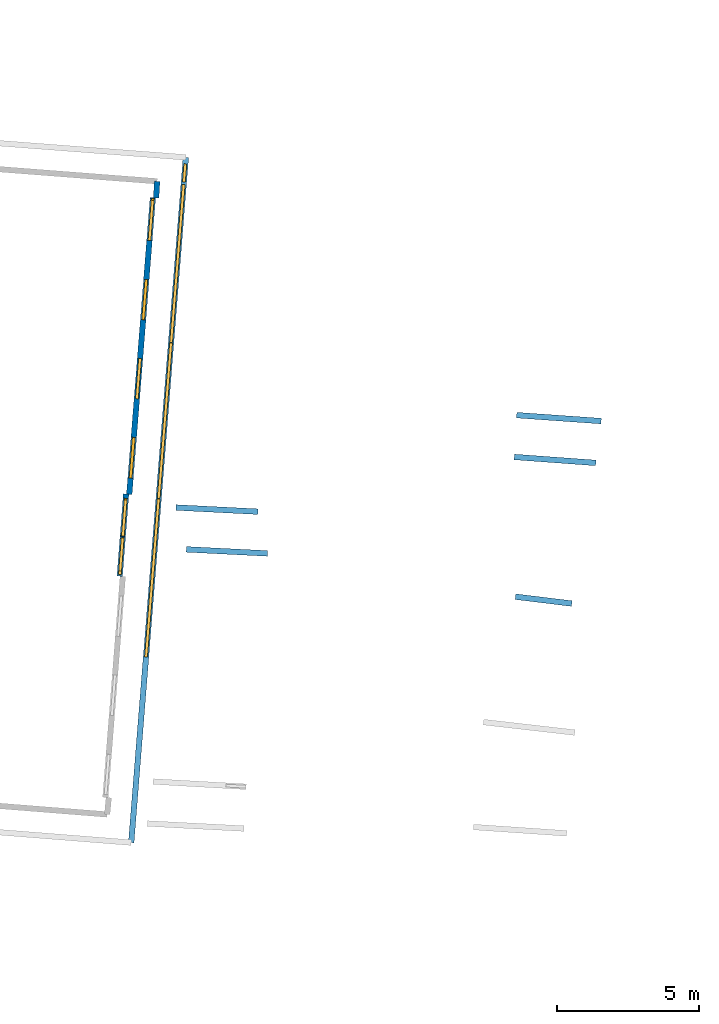
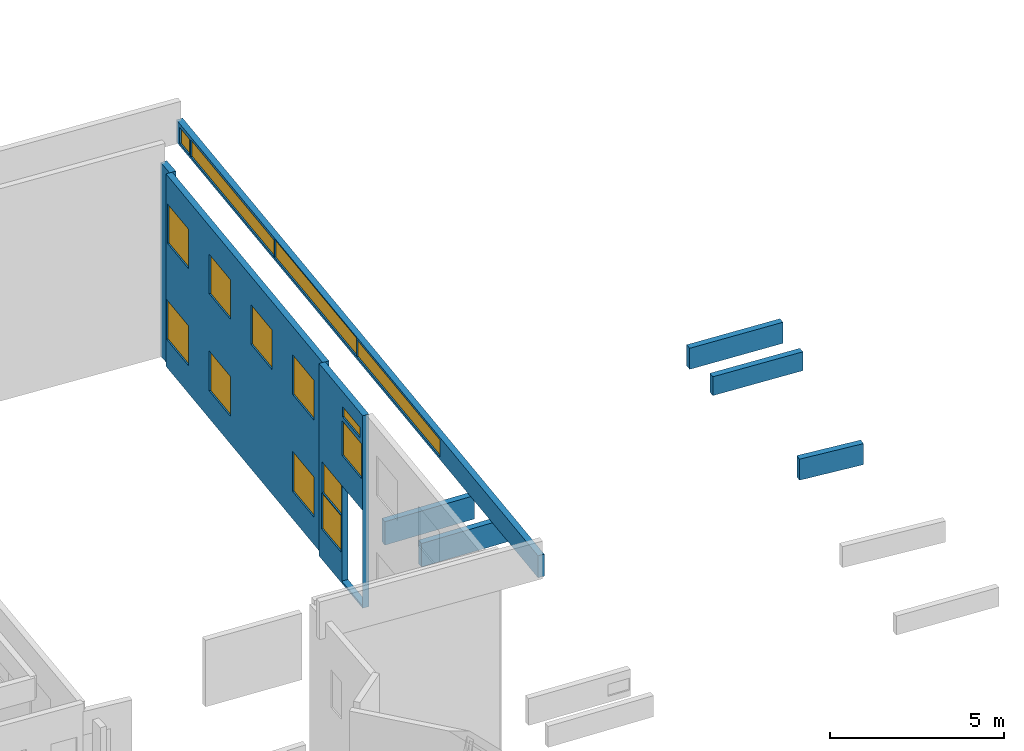
# One storey, part 24 of 27: 15 windows, 9 walls, 16 openings.
"""IFC2X3 building model written with IfcOpenShell, lengths in metres."""

from ifc_helpers import new_model, entity, si_unit, converted_unit, derived_unit, direction, frame, frame_2d, origin, origin_2d_with_axis, place, context, subcontext, project, spatial, polyline, rectangle, outline, extrude, source, transform, mapped, material, layer, layer_set, layer_usage, type_object, type_shapes, element, fill, save


model = new_model("IFC2X3")

# Units and contexts
model_context = context("Model", 3, precision=1e-05, world=origin(), true_north=direction((0.0, 1.0)))
body_context = subcontext(model_context, "Body", "Model", "MODEL_VIEW")
ifc_project = project(units=[si_unit("LENGTHUNIT", "METRE"), si_unit("AREAUNIT", "SQUARE_METRE"), si_unit("VOLUMEUNIT", "CUBIC_METRE"), converted_unit("PLANEANGLEUNIT", "DEGREE", entity("IfcRatioMeasure", 0.0174532925199433), si_unit("PLANEANGLEUNIT", "RADIAN"), dimensions=[0, 0, 0, 0, 0, 0, 0]), si_unit("MASSUNIT", "GRAM", prefix="KILO"), derived_unit("MASSDENSITYUNIT", [(si_unit("MASSUNIT", "GRAM", prefix="KILO"), 1), (si_unit("LENGTHUNIT", "METRE"), -3)]), derived_unit("MOMENTOFINERTIAUNIT", [(si_unit("LENGTHUNIT", "METRE"), 4)]), si_unit("TIMEUNIT", "SECOND"), si_unit("FREQUENCYUNIT", "HERTZ"), si_unit("THERMODYNAMICTEMPERATUREUNIT", "DEGREE_CELSIUS"), derived_unit("THERMALTRANSMITTANCEUNIT", [(si_unit("MASSUNIT", "GRAM", prefix="KILO"), 1), (si_unit("THERMODYNAMICTEMPERATUREUNIT", "KELVIN"), -1), (si_unit("TIMEUNIT", "SECOND"), -3)]), derived_unit("VOLUMETRICFLOWRATEUNIT", [(si_unit("LENGTHUNIT", "METRE"), 3), (si_unit("TIMEUNIT", "SECOND"), -1)]), si_unit("ELECTRICCURRENTUNIT", "AMPERE"), si_unit("ELECTRICVOLTAGEUNIT", "VOLT"), si_unit("POWERUNIT", "WATT"), si_unit("FORCEUNIT", "NEWTON", prefix="KILO"), si_unit("ILLUMINANCEUNIT", "LUX"), si_unit("LUMINOUSFLUXUNIT", "LUMEN"), si_unit("LUMINOUSINTENSITYUNIT", "CANDELA"), derived_unit("USERDEFINED", [(si_unit("MASSUNIT", "GRAM", prefix="KILO"), -1), (si_unit("LENGTHUNIT", "METRE"), -2), (si_unit("TIMEUNIT", "SECOND"), 3), (si_unit("LUMINOUSFLUXUNIT", "LUMEN"), 1)]), derived_unit("LINEARVELOCITYUNIT", [(si_unit("LENGTHUNIT", "METRE"), 1), (si_unit("TIMEUNIT", "SECOND"), -1)]), si_unit("PRESSUREUNIT", "PASCAL"), derived_unit("USERDEFINED", [(si_unit("LENGTHUNIT", "METRE"), -2), (si_unit("MASSUNIT", "GRAM", prefix="KILO"), 1), (si_unit("TIMEUNIT", "SECOND"), -2)]), derived_unit("LINEARFORCEUNIT", [(si_unit("MASSUNIT", "GRAM", prefix="KILO"), 1), (si_unit("LENGTHUNIT", "METRE"), 1), (si_unit("TIMEUNIT", "SECOND"), -2), (si_unit("LENGTHUNIT", "METRE"), -1)]), derived_unit("PLANARFORCEUNIT", [(si_unit("MASSUNIT", "GRAM", prefix="KILO"), 1), (si_unit("LENGTHUNIT", "METRE"), 1), (si_unit("TIMEUNIT", "SECOND"), -2), (si_unit("LENGTHUNIT", "METRE"), -2)])], contexts=[model_context])

# Site, building, storey
placement_1 = place(None, origin())
site = spatial("IfcSite", under=ifc_project, at=placement_1, CompositionType="ELEMENT")
building = spatial("IfcBuilding", under=site, at=placement_1, CompositionType="ELEMENT")
storey_placement = place(placement_1, frame((0.0, 0.0, -61.043098449707)))
storey = spatial("IfcBuildingStorey", under=building, at=storey_placement, Name="level_-61.043098", CompositionType="ELEMENT", Elevation=-61.043098449707)

# Wall, openings, windows
ifc_material_1 = material(Name="Default wall")
ifc_layer = layer(ifc_material_1, 0.2)
ifc_layer_set = layer_set([ifc_layer], Name="wall_thickness_0.2000")
ifc_layer_usage = layer_usage(ifc_layer_set, "AXIS2", "POSITIVE", -0.1)
wall_type = type_object("IfcWallType", Name="wall_thickness_0.2000", PredefinedType="STANDARD", material=ifc_layer_set)
wall_1_placement = place(storey_placement, frame((19.830706267679, 16.3471180703167, 0.0), z_axis=(0.0, 0.0, 1.0), x_axis=(-0.0793045505600574, -0.996850434248021, 0.0)))
wall_1 = element("IfcWallStandardCase", 1, at=wall_1_placement, inside=storey, type_object=wall_type, material=ifc_layer_usage, Name="Wall:148", ObjectType="Wall", context=body_context, shape_type="SweptSolid", body=[
    extrude(outline(polyline([(10.4892864111409, -0.1), (10.4892864111409, 0.1), (0.0, 0.1), (0.0, -0.1), (10.4892864111409, -0.1)])), origin(), (0.0, 0.0, 1.0), 6.76219177246094),
])
opening_1_placement = place(wall_1_placement, frame((0.0944787306593776, -0.1, 4.38393783569336)))
opening_1 = element("IfcOpeningElement", 2, at=opening_1_placement, cuts=wall_1, Name="Opening : 1420 x 1385 : 4", ObjectType="Opening", context=body_context, shape_type="SweptSolid", body=[
    extrude(rectangle(XDim=1.42, YDim=1.385, at=frame_2d((0.6925, 0.71), x_axis=(0.0, 1.0))), frame((0.0, 0.0, 0.0), z_axis=(0.0, 1.0, 0.0), x_axis=(0.0, 0.0, 1.0)), (0.0, 0.0, 1.0), 0.2),
])
opening_2_placement = place(wall_1_placement, frame((2.89447898909143, -0.1, 4.37893676757812)))
opening_2 = element("IfcOpeningElement", 3, at=opening_2_placement, cuts=wall_1, Name="Opening : 1420 x 1390 : 5", ObjectType="Opening", context=body_context, shape_type="SweptSolid", body=[
    extrude(rectangle(XDim=1.42, YDim=1.39, at=frame_2d((0.695, 0.71), x_axis=(0.0, 1.0))), frame((0.0, 0.0, 0.0), z_axis=(0.0, 1.0, 0.0), x_axis=(0.0, 0.0, 1.0)), (0.0, 0.0, 1.0), 0.2),
])
opening_3_placement = place(wall_1_placement, frame((0.0344790725119533, -0.1, 0.97393798828125)))
opening_3 = element("IfcOpeningElement", 4, at=opening_3_placement, cuts=wall_1, Name="Opening : 1480 x 1400 : 6", ObjectType="Opening", context=body_context, shape_type="SweptSolid", body=[
    extrude(rectangle(XDim=1.48, YDim=1.4, at=frame_2d((0.7, 0.74), x_axis=(0.0, 1.0))), frame((0.0, 0.0, 0.0), z_axis=(0.0, 1.0, 0.0), x_axis=(0.0, 0.0, 1.0)), (0.0, 0.0, 1.0), 0.2),
])
opening_4_placement = place(wall_1_placement, frame((2.89447898909143, -0.1, 0.968936920166016)))
opening_4 = element("IfcOpeningElement", 5, at=opening_4_placement, cuts=wall_1, Name="Opening : 1425 x 1400 : 7", ObjectType="Opening", context=body_context, shape_type="SweptSolid", body=[
    extrude(rectangle(XDim=1.425, YDim=1.4, at=frame_2d((0.7, 0.7125), x_axis=(0.0, 1.0))), frame((0.0, 0.0, 0.0), z_axis=(0.0, 1.0, 0.0), x_axis=(0.0, 0.0, 1.0)), (0.0, 0.0, 1.0), 0.2),
])
opening_5_placement = place(wall_1_placement, frame((8.48262642716202, -0.1, 4.37436294555664)))
opening_5 = element("IfcOpeningElement", 6, at=opening_5_placement, cuts=wall_1, Name="Opening : 1425 x 1395 : 8", ObjectType="Opening", context=body_context, shape_type="SweptSolid", body=[
    extrude(rectangle(XDim=1.425, YDim=1.395, at=frame_2d((0.6975, 0.7125), x_axis=(0.0, 1.0))), frame((0.0, 0.0, 0.0), z_axis=(0.0, 1.0, 0.0), x_axis=(0.0, 0.0, 1.0)), (0.0, 0.0, 1.0), 0.2),
])
opening_6_placement = place(wall_1_placement, frame((5.6826269681392, -0.1, 4.37436294555664)))
opening_6 = element("IfcOpeningElement", 7, at=opening_6_placement, cuts=wall_1, Name="Opening : 1430 x 1390 : 9", ObjectType="Opening", context=body_context, shape_type="SweptSolid", body=[
    extrude(rectangle(XDim=1.43, YDim=1.39, at=frame_2d((0.695, 0.715), x_axis=(0.0, 1.0))), frame((0.0, 0.0, 0.0), z_axis=(0.0, 1.0, 0.0), x_axis=(0.0, 0.0, 1.0)), (0.0, 0.0, 1.0), 0.2),
])
opening_7_placement = place(wall_1_placement, frame((8.474478762893, -0.1, 0.963935852050781)))
opening_7 = element("IfcOpeningElement", 8, at=opening_7_placement, cuts=wall_1, Name="Opening : 1445 x 1410 : 10", ObjectType="Opening", context=body_context, shape_type="SweptSolid", body=[
    extrude(rectangle(XDim=1.445, YDim=1.41, at=frame_2d((0.705, 0.7225), x_axis=(0.0, 1.0))), frame((0.0, 0.0, 0.0), z_axis=(0.0, 1.0, 0.0), x_axis=(0.0, 0.0, 1.0)), (0.0, 0.0, 1.0), 0.2),
])
ifc_material_2 = material(Name="Window Default")
window_style_1 = type_object("IfcWindowStyle", Name="Window : 1420 x 1385mm", ConstructionType="NOTDEFINED", OperationType="NOTDEFINED", ParameterTakesPrecedence=False, Sizeable=False, material=ifc_material_2)
shared_shape_1 = source(origin(), body_context, "Body", "SweptSolid", [
    extrude(rectangle(XDim=0.1, YDim=1.42, at=origin_2d_with_axis()), frame((0.71, 0.1, 0.0), z_axis=(0.0, 0.0, 1.0), x_axis=(0.0, 1.0, 0.0)), (0.0, 0.0, 1.0), 1.385),
])
type_shapes(window_style_1, [shared_shape_1])
window_1_placement = place(opening_1_placement, origin())
window_1 = element("IfcWindow", 9, at=window_1_placement, inside=storey, type_object=window_style_1, Name="Window : 1420 x 1385mm : 3", ObjectType="Window : 1420 x 1385mm", OverallHeight=1.385, OverallWidth=1.42, context=body_context, shape_type="MappedRepresentation", body=[
    mapped(shared_shape_1, transform((0.0, 0.0, 0.0), scale=1.0)),
])
fill(opening_1, window_1)
window_style_2 = type_object("IfcWindowStyle", Name="Window : 1420 x 1390mm", ConstructionType="NOTDEFINED", OperationType="NOTDEFINED", ParameterTakesPrecedence=False, Sizeable=False, material=ifc_material_2)
shared_shape_2 = source(origin(), body_context, "Body", "SweptSolid", [
    extrude(rectangle(XDim=0.1, YDim=1.42, at=origin_2d_with_axis()), frame((0.71, 0.1, 0.0), z_axis=(0.0, 0.0, 1.0), x_axis=(0.0, 1.0, 0.0)), (0.0, 0.0, 1.0), 1.39),
])
type_shapes(window_style_2, [shared_shape_2])
window_2_placement = place(opening_2_placement, origin())
window_2 = element("IfcWindow", 10, at=window_2_placement, inside=storey, type_object=window_style_2, Name="Window : 1420 x 1390mm : 4", ObjectType="Window : 1420 x 1390mm", OverallHeight=1.39, OverallWidth=1.42, context=body_context, shape_type="MappedRepresentation", body=[
    mapped(shared_shape_2, transform((0.0, 0.0, 0.0), scale=1.0)),
])
fill(opening_2, window_2)
window_style_3 = type_object("IfcWindowStyle", Name="Window : 1480 x 1400mm", ConstructionType="NOTDEFINED", OperationType="NOTDEFINED", ParameterTakesPrecedence=False, Sizeable=False, material=ifc_material_2)
shared_shape_3 = source(origin(), body_context, "Body", "SweptSolid", [
    extrude(rectangle(XDim=0.1, YDim=1.48, at=origin_2d_with_axis()), frame((0.74, 0.1, 0.0), z_axis=(0.0, 0.0, 1.0), x_axis=(0.0, 1.0, 0.0)), (0.0, 0.0, 1.0), 1.4),
])
type_shapes(window_style_3, [shared_shape_3])
window_3_placement = place(opening_3_placement, origin())
window_3 = element("IfcWindow", 11, at=window_3_placement, inside=storey, type_object=window_style_3, Name="Window : 1480 x 1400mm : 5", ObjectType="Window : 1480 x 1400mm", OverallHeight=1.4, OverallWidth=1.48, context=body_context, shape_type="MappedRepresentation", body=[
    mapped(shared_shape_3, transform((0.0, 0.0, 0.0), scale=1.0)),
])
fill(opening_3, window_3)
window_style_4 = type_object("IfcWindowStyle", Name="Window : 1425 x 1400mm", ConstructionType="NOTDEFINED", OperationType="NOTDEFINED", ParameterTakesPrecedence=False, Sizeable=False, material=ifc_material_2)
shared_shape_4 = source(origin(), body_context, "Body", "SweptSolid", [
    extrude(rectangle(XDim=0.1, YDim=1.425, at=origin_2d_with_axis()), frame((0.7125, 0.1, 0.0), z_axis=(0.0, 0.0, 1.0), x_axis=(0.0, 1.0, 0.0)), (0.0, 0.0, 1.0), 1.4),
])
type_shapes(window_style_4, [shared_shape_4])
window_4_placement = place(opening_4_placement, origin())
window_4 = element("IfcWindow", 12, at=window_4_placement, inside=storey, type_object=window_style_4, Name="Window : 1425 x 1400mm : 6", ObjectType="Window : 1425 x 1400mm", OverallHeight=1.4, OverallWidth=1.425, context=body_context, shape_type="MappedRepresentation", body=[
    mapped(shared_shape_4, transform((0.0, 0.0, 0.0), scale=1.0)),
])
fill(opening_4, window_4)
window_style_5 = type_object("IfcWindowStyle", Name="Window : 1425 x 1395mm", ConstructionType="NOTDEFINED", OperationType="NOTDEFINED", ParameterTakesPrecedence=False, Sizeable=False, material=ifc_material_2)
shared_shape_5 = source(origin(), body_context, "Body", "SweptSolid", [
    extrude(rectangle(XDim=0.1, YDim=1.425, at=origin_2d_with_axis()), frame((0.7125, 0.1, 0.0), z_axis=(0.0, 0.0, 1.0), x_axis=(0.0, 1.0, 0.0)), (0.0, 0.0, 1.0), 1.395),
])
type_shapes(window_style_5, [shared_shape_5])
window_5_placement = place(opening_5_placement, origin())
window_5 = element("IfcWindow", 13, at=window_5_placement, inside=storey, type_object=window_style_5, Name="Window : 1425 x 1395mm : 7", ObjectType="Window : 1425 x 1395mm", OverallHeight=1.395, OverallWidth=1.425, context=body_context, shape_type="MappedRepresentation", body=[
    mapped(shared_shape_5, transform((0.0, 0.0, 0.0), scale=1.0)),
])
fill(opening_5, window_5)
window_style_6 = type_object("IfcWindowStyle", Name="Window : 1430 x 1390mm", ConstructionType="NOTDEFINED", OperationType="NOTDEFINED", ParameterTakesPrecedence=False, Sizeable=False, material=ifc_material_2)
shared_shape_6 = source(origin(), body_context, "Body", "SweptSolid", [
    extrude(rectangle(XDim=0.1, YDim=1.43, at=origin_2d_with_axis()), frame((0.715, 0.1, 0.0), z_axis=(0.0, 0.0, 1.0), x_axis=(0.0, 1.0, 0.0)), (0.0, 0.0, 1.0), 1.39),
])
type_shapes(window_style_6, [shared_shape_6])
window_6_placement = place(opening_6_placement, origin())
window_6 = element("IfcWindow", 14, at=window_6_placement, inside=storey, type_object=window_style_6, Name="Window : 1430 x 1390mm : 8", ObjectType="Window : 1430 x 1390mm", OverallHeight=1.39, OverallWidth=1.43, context=body_context, shape_type="MappedRepresentation", body=[
    mapped(shared_shape_6, transform((0.0, 0.0, 0.0), scale=1.0)),
])
fill(opening_6, window_6)
window_style_7 = type_object("IfcWindowStyle", Name="Window : 1445 x 1410mm", ConstructionType="NOTDEFINED", OperationType="NOTDEFINED", ParameterTakesPrecedence=False, Sizeable=False, material=ifc_material_2)
shared_shape_7 = source(origin(), body_context, "Body", "SweptSolid", [
    extrude(rectangle(XDim=0.1, YDim=1.445, at=origin_2d_with_axis()), frame((0.7225, 0.1, 0.0), z_axis=(0.0, 0.0, 1.0), x_axis=(0.0, 1.0, 0.0)), (0.0, 0.0, 1.0), 1.41),
])
type_shapes(window_style_7, [shared_shape_7])
window_7_placement = place(opening_7_placement, origin())
window_7 = element("IfcWindow", 15, at=window_7_placement, inside=storey, type_object=window_style_7, Name="Window : 1445 x 1410mm : 9", ObjectType="Window : 1445 x 1410mm", OverallHeight=1.41, OverallWidth=1.445, context=body_context, shape_type="MappedRepresentation", body=[
    mapped(shared_shape_7, transform((0.0, 0.0, 0.0), scale=1.0)),
])
fill(opening_7, window_7)

# Wall
placement_2 = place(placement_1, frame((0.0, 0.0, -60.9578857421875)))
wall_2_placement = place(placement_2, frame((20.6454019462022, 5.42498216268091, 0.0), z_axis=(0.0, 0.0, 1.0), x_axis=(0.998710668133516, -0.0507641739448691, 0.0)))
element("IfcWallStandardCase", 16, at=wall_2_placement, inside=storey, type_object=wall_type, material=ifc_layer_usage, Name="Wall:423", ObjectType="Wall", context=body_context, shape_type="SweptSolid", body=[
    extrude(outline(polyline([(2.89000050751705, -0.1), (2.89000050751705, 0.1), (0.0, 0.1), (0.0, -0.1), (2.89000050751705, -0.1)])), origin(), (0.0, 0.0, 1.0), 0.824409484863281),
])

# Wall, openings, windows
wall_3_placement = place(storey_placement, frame((18.8875412088845, 5.90455140736955, 0.0), z_axis=(0.0, 0.0, 1.0), x_axis=(-0.0773321918862994, -0.99700538218109, 0.0)))
wall_3 = element("IfcWallStandardCase", 17, at=wall_3_placement, inside=storey, type_object=wall_type, material=ifc_layer_usage, Name="Wall:634", ObjectType="Wall", context=body_context, shape_type="SweptSolid", body=[
    extrude(outline(polyline([(2.91088717588014, -0.1), (2.91088717588014, 0.1), (0.0, 0.1), (0.0, -0.1), (2.91088717588014, -0.1)])), origin(), (0.0, 0.0, 1.0), 6.76219177246094),
])
opening_8_placement = place(wall_3_placement, frame((1.51588720520371, -0.1, 0.0727729797363281)))
element("IfcOpeningElement", 18, at=opening_8_placement, cuts=wall_3, Name="Opening : 1390 x 3360 : 49", ObjectType="Opening", context=body_context, shape_type="SweptSolid", body=[
    extrude(rectangle(XDim=1.39, YDim=3.36, at=frame_2d((1.68, 0.695), x_axis=(0.0, 1.0))), frame((0.0, 0.0, 0.0), z_axis=(0.0, 1.0, 0.0), x_axis=(0.0, 0.0, 1.0)), (0.0, 0.0, 1.0), 0.2),
])
opening_9_placement = place(wall_3_placement, frame((1.56588703945985, -0.1, 5.87777328491211)))
opening_9 = element("IfcOpeningElement", 19, at=opening_9_placement, cuts=wall_3, Name="Opening : 1165 x 360 : 50", ObjectType="Opening", context=body_context, shape_type="SweptSolid", body=[
    extrude(rectangle(XDim=1.165, YDim=0.36, at=frame_2d((0.18, 0.5825), x_axis=(0.0, 1.0))), frame((0.0, 0.0, 0.0), z_axis=(0.0, 1.0, 0.0), x_axis=(0.0, 0.0, 1.0)), (0.0, 0.0, 1.0), 0.2),
])
opening_10_placement = place(wall_3_placement, frame((1.54088736003638, -0.1, 4.50277328491211)))
opening_10 = element("IfcOpeningElement", 20, at=opening_10_placement, cuts=wall_3, Name="Opening : 1305 x 1225 : 51", ObjectType="Opening", context=body_context, shape_type="SweptSolid", body=[
    extrude(rectangle(XDim=1.305, YDim=1.225, at=frame_2d((0.6125, 0.6525), x_axis=(0.0, 1.0))), frame((0.0, 0.0, 0.0), z_axis=(0.0, 1.0, 0.0), x_axis=(0.0, 0.0, 1.0)), (0.0, 0.0, 1.0), 0.2),
])
opening_11_placement = place(wall_3_placement, frame((0.210887135182291, -0.1, 2.36277008056641)))
opening_11 = element("IfcOpeningElement", 21, at=opening_11_placement, cuts=wall_3, Name="Opening : 1275 x 1070 : 52", ObjectType="Opening", context=body_context, shape_type="SweptSolid", body=[
    extrude(rectangle(XDim=1.275, YDim=1.07, at=frame_2d((0.535, 0.6375), x_axis=(0.0, 1.0))), frame((0.0, 0.0, 0.0), z_axis=(0.0, 1.0, 0.0), x_axis=(0.0, 0.0, 1.0)), (0.0, 0.0, 1.0), 0.2),
])
opening_12_placement = place(wall_3_placement, frame((0.155887102713644, -0.1, 1.06277084350586)))
opening_12 = element("IfcOpeningElement", 22, at=opening_12_placement, cuts=wall_3, Name="Opening : 1325 x 1270 : 53", ObjectType="Opening", context=body_context, shape_type="SweptSolid", body=[
    extrude(rectangle(XDim=1.325, YDim=1.27, at=frame_2d((0.635, 0.6625), x_axis=(0.0, 1.0))), frame((0.0, 0.0, 0.0), z_axis=(0.0, 1.0, 0.0), x_axis=(0.0, 0.0, 1.0)), (0.0, 0.0, 1.0), 0.2),
])
window_style_8 = type_object("IfcWindowStyle", Name="Window : 1165 x 360mm", ConstructionType="NOTDEFINED", OperationType="NOTDEFINED", ParameterTakesPrecedence=False, Sizeable=False, material=ifc_material_2)
shared_shape_8 = source(origin(), body_context, "Body", "SweptSolid", [
    extrude(rectangle(XDim=0.1, YDim=1.165, at=origin_2d_with_axis()), frame((0.5825, 0.1, 0.0), z_axis=(0.0, 0.0, 1.0), x_axis=(0.0, 1.0, 0.0)), (0.0, 0.0, 1.0), 0.36),
])
type_shapes(window_style_8, [shared_shape_8])
window_8_placement = place(opening_9_placement, origin())
window_8 = element("IfcWindow", 23, at=window_8_placement, inside=storey, type_object=window_style_8, Name="Window : 1165 x 360mm : 42", ObjectType="Window : 1165 x 360mm", OverallHeight=0.36, OverallWidth=1.165, context=body_context, shape_type="MappedRepresentation", body=[
    mapped(shared_shape_8, transform((0.0, 0.0, 0.0), scale=1.0)),
])
fill(opening_9, window_8)
window_style_9 = type_object("IfcWindowStyle", Name="Window : 1305 x 1225mm", ConstructionType="NOTDEFINED", OperationType="NOTDEFINED", ParameterTakesPrecedence=False, Sizeable=False, material=ifc_material_2)
shared_shape_9 = source(origin(), body_context, "Body", "SweptSolid", [
    extrude(rectangle(XDim=0.1, YDim=1.305, at=origin_2d_with_axis()), frame((0.6525, 0.1, 0.0), z_axis=(0.0, 0.0, 1.0), x_axis=(0.0, 1.0, 0.0)), (0.0, 0.0, 1.0), 1.225),
])
type_shapes(window_style_9, [shared_shape_9])
window_9_placement = place(opening_10_placement, origin())
window_9 = element("IfcWindow", 24, at=window_9_placement, inside=storey, type_object=window_style_9, Name="Window : 1305 x 1225mm : 43", ObjectType="Window : 1305 x 1225mm", OverallHeight=1.225, OverallWidth=1.305, context=body_context, shape_type="MappedRepresentation", body=[
    mapped(shared_shape_9, transform((0.0, 0.0, 0.0), scale=1.0)),
])
fill(opening_10, window_9)
window_style_10 = type_object("IfcWindowStyle", Name="Window : 1275 x 1070mm", ConstructionType="NOTDEFINED", OperationType="NOTDEFINED", ParameterTakesPrecedence=False, Sizeable=False, material=ifc_material_2)
shared_shape_10 = source(origin(), body_context, "Body", "SweptSolid", [
    extrude(rectangle(XDim=0.1, YDim=1.275, at=origin_2d_with_axis()), frame((0.6375, 0.1, 0.0), z_axis=(0.0, 0.0, 1.0), x_axis=(0.0, 1.0, 0.0)), (0.0, 0.0, 1.0), 1.07),
])
type_shapes(window_style_10, [shared_shape_10])
window_10_placement = place(opening_11_placement, origin())
window_10 = element("IfcWindow", 25, at=window_10_placement, inside=storey, type_object=window_style_10, Name="Window : 1275 x 1070mm : 44", ObjectType="Window : 1275 x 1070mm", OverallHeight=1.07, OverallWidth=1.275, context=body_context, shape_type="MappedRepresentation", body=[
    mapped(shared_shape_10, transform((0.0, 0.0, 0.0), scale=1.0)),
])
fill(opening_11, window_10)
window_style_11 = type_object("IfcWindowStyle", Name="Window : 1325 x 1270mm", ConstructionType="NOTDEFINED", OperationType="NOTDEFINED", ParameterTakesPrecedence=False, Sizeable=False, material=ifc_material_2)
shared_shape_11 = source(origin(), body_context, "Body", "SweptSolid", [
    extrude(rectangle(XDim=0.1, YDim=1.325, at=origin_2d_with_axis()), frame((0.6625, 0.1, 0.0), z_axis=(0.0, 0.0, 1.0), x_axis=(0.0, 1.0, 0.0)), (0.0, 0.0, 1.0), 1.27),
])
type_shapes(window_style_11, [shared_shape_11])
window_11_placement = place(opening_12_placement, origin())
window_11 = element("IfcWindow", 26, at=window_11_placement, inside=storey, type_object=window_style_11, Name="Window : 1325 x 1270mm : 45", ObjectType="Window : 1325 x 1270mm", OverallHeight=1.27, OverallWidth=1.325, context=body_context, shape_type="MappedRepresentation", body=[
    mapped(shared_shape_11, transform((0.0, 0.0, 0.0), scale=1.0)),
])
fill(opening_12, window_11)

# Walls
placement_3 = place(placement_1, frame((0.0, 0.0, -60.9578857421875)))
wall_4_placement = place(placement_3, frame((32.6116410192423, 2.28167485912491, 0.0), z_axis=(0.0, 0.0, 1.0), x_axis=(0.992600889832086, -0.121422705885478, 0.0)))
element("IfcWallStandardCase", 27, at=wall_4_placement, inside=storey, type_object=wall_type, material=ifc_layer_usage, Name="Wall:654", ObjectType="Wall", context=body_context, shape_type="SweptSolid", body=[
    extrude(outline(polyline([(2.00000101716861, -0.1), (2.00000101716861, 0.1), (0.0, 0.1), (0.0, -0.1), (2.00000101716861, -0.1)])), origin(), (0.0, 0.0, 1.0), 0.739894866943359),
])
placement_4 = place(placement_1, frame((0.0, 0.0, -60.9578857421875)))
wall_5_placement = place(placement_4, frame((32.5697647360604, 7.20629309691356, 0.0), z_axis=(0.0, 0.0, 1.0), x_axis=(0.997338203872397, -0.0729143819598049, 0.0)))
element("IfcWallStandardCase", 28, at=wall_5_placement, inside=storey, type_object=wall_type, material=ifc_layer_usage, Name="Wall:878", ObjectType="Wall", context=body_context, shape_type="SweptSolid", body=[
    extrude(outline(polyline([(2.88071857524557, -0.1), (2.88071857524557, 0.1), (0.0, 0.1), (0.0, -0.1), (2.88071857524557, -0.1)])), origin(), (0.0, 0.0, 1.0), 0.661750793457031),
])
placement_5 = place(placement_1, frame((0.0, 0.0, -61.0783157348633)))
wall_6_placement = place(placement_5, frame((19.9817576609371, 16.9220715234578, 0.0), z_axis=(0.0, 0.0, 1.0), x_axis=(-0.0603520913472466, -0.998177151146035, 0.0)))
element("IfcWallStandardCase", 29, at=wall_6_placement, inside=storey, type_object=wall_type, material=ifc_layer_usage, Name="Wall:1117", ObjectType="Wall", context=body_context, shape_type="SweptSolid", body=[
    extrude(outline(polyline([(0.584857840231885, -0.1), (0.584857840231885, 0.1), (0.0, 0.1), (0.0, -0.1), (0.584857840231885, -0.1)])), origin(), (0.0, 0.0, 1.0), 6.79740905761719),
])

# Wall, openings, windows
placement_6 = place(placement_1, frame((0.0, 0.0, -54.4207000732422)))
wall_7_placement = place(placement_6, frame((19.0679512129911, -6.38680164654442, 0.0), z_axis=(0.0, 0.0, 1.0), x_axis=(0.0794642046496998, 0.996837720082557, 0.0)))
wall_7 = element("IfcWallStandardCase", 30, at=wall_7_placement, inside=storey, type_object=wall_type, material=ifc_layer_usage, Name="Wall:1223", ObjectType="Wall", context=body_context, shape_type="SweptSolid", body=[
    extrude(outline(polyline([(24.2293667171808, -0.1), (24.2293667171808, 0.1), (0.0, 0.1), (0.0, -0.1), (24.2293667171808, -0.1)])), origin(), (0.0, 0.0, 1.0), 0.772296905517578),
])
opening_13_placement = place(wall_7_placement, frame((12.1622430587236, -0.1, 0.0889358520507812)))
opening_13 = element("IfcOpeningElement", 31, at=opening_13_placement, cuts=wall_7, Name="Opening : 5505 x 645 : 165", ObjectType="Opening", context=body_context, shape_type="SweptSolid", body=[
    extrude(rectangle(XDim=5.505, YDim=0.645, at=frame_2d((0.3225, 2.7525), x_axis=(0.0, 1.0))), frame((0.0, 0.0, 0.0), z_axis=(0.0, 1.0, 0.0), x_axis=(0.0, 0.0, 1.0)), (0.0, 0.0, 1.0), 0.2),
])
opening_14_placement = place(wall_7_placement, frame((6.56724281997604, -0.1, 0.0889358520507812)))
opening_14 = element("IfcOpeningElement", 32, at=opening_14_placement, cuts=wall_7, Name="Opening : 5580 x 605 : 166", ObjectType="Opening", context=body_context, shape_type="SweptSolid", body=[
    extrude(rectangle(XDim=5.58, YDim=0.605, at=frame_2d((0.3025, 2.79), x_axis=(0.0, 1.0))), frame((0.0, 0.0, 0.0), z_axis=(0.0, 1.0, 0.0), x_axis=(0.0, 0.0, 1.0)), (0.0, 0.0, 1.0), 0.2),
])
opening_15_placement = place(wall_7_placement, frame((17.6872438715315, -0.1, 0.0839347839355469)))
opening_15 = element("IfcOpeningElement", 33, at=opening_15_placement, cuts=wall_7, Name="Opening : 5585 x 595 : 167", ObjectType="Opening", context=body_context, shape_type="SweptSolid", body=[
    extrude(rectangle(XDim=5.585, YDim=0.595, at=frame_2d((0.2975, 2.7925), x_axis=(0.0, 1.0))), frame((0.0, 0.0, 0.0), z_axis=(0.0, 1.0, 0.0), x_axis=(0.0, 0.0, 1.0)), (0.0, 0.0, 1.0), 0.2),
])
opening_16_placement = place(wall_7_placement, frame((23.3572449531702, -0.1, 0.0839347839355469)))
opening_16 = element("IfcOpeningElement", 34, at=opening_16_placement, cuts=wall_7, Name="Opening : 645 x 560 : 168", ObjectType="Opening", context=body_context, shape_type="SweptSolid", body=[
    extrude(rectangle(XDim=0.645, YDim=0.56, at=frame_2d((0.28, 0.3225), x_axis=(0.0, 1.0))), frame((0.0, 0.0, 0.0), z_axis=(0.0, 1.0, 0.0), x_axis=(0.0, 0.0, 1.0)), (0.0, 0.0, 1.0), 0.2),
])
window_style_12 = type_object("IfcWindowStyle", Name="Window : 5505 x 645mm", ConstructionType="NOTDEFINED", OperationType="NOTDEFINED", ParameterTakesPrecedence=False, Sizeable=False, material=ifc_material_2)
shared_shape_12 = source(origin(), body_context, "Body", "SweptSolid", [
    extrude(rectangle(XDim=0.1, YDim=5.505, at=origin_2d_with_axis()), frame((2.7525, 0.1, 0.0), z_axis=(0.0, 0.0, 1.0), x_axis=(0.0, 1.0, 0.0)), (0.0, 0.0, 1.0), 0.645),
])
type_shapes(window_style_12, [shared_shape_12])
window_12_placement = place(opening_13_placement, origin())
window_12 = element("IfcWindow", 35, at=window_12_placement, inside=storey, type_object=window_style_12, Name="Window : 5505 x 645mm : 150", ObjectType="Window : 5505 x 645mm", OverallHeight=0.645, OverallWidth=5.505, context=body_context, shape_type="MappedRepresentation", body=[
    mapped(shared_shape_12, transform((0.0, 0.0, 0.0), scale=1.0)),
])
fill(opening_13, window_12)
window_style_13 = type_object("IfcWindowStyle", Name="Window : 5580 x 605mm", ConstructionType="NOTDEFINED", OperationType="NOTDEFINED", ParameterTakesPrecedence=False, Sizeable=False, material=ifc_material_2)
shared_shape_13 = source(origin(), body_context, "Body", "SweptSolid", [
    extrude(rectangle(XDim=0.1, YDim=5.58, at=origin_2d_with_axis()), frame((2.79, 0.1, 0.0), z_axis=(0.0, 0.0, 1.0), x_axis=(0.0, 1.0, 0.0)), (0.0, 0.0, 1.0), 0.605),
])
type_shapes(window_style_13, [shared_shape_13])
window_13_placement = place(opening_14_placement, origin())
window_13 = element("IfcWindow", 36, at=window_13_placement, inside=storey, type_object=window_style_13, Name="Window : 5580 x 605mm : 151", ObjectType="Window : 5580 x 605mm", OverallHeight=0.605, OverallWidth=5.58, context=body_context, shape_type="MappedRepresentation", body=[
    mapped(shared_shape_13, transform((0.0, 0.0, 0.0), scale=1.0)),
])
fill(opening_14, window_13)
window_style_14 = type_object("IfcWindowStyle", Name="Window : 5585 x 595mm", ConstructionType="NOTDEFINED", OperationType="NOTDEFINED", ParameterTakesPrecedence=False, Sizeable=False, material=ifc_material_2)
shared_shape_14 = source(origin(), body_context, "Body", "SweptSolid", [
    extrude(rectangle(XDim=0.1, YDim=5.585, at=origin_2d_with_axis()), frame((2.7925, 0.1, 0.0), z_axis=(0.0, 0.0, 1.0), x_axis=(0.0, 1.0, 0.0)), (0.0, 0.0, 1.0), 0.595),
])
type_shapes(window_style_14, [shared_shape_14])
window_14_placement = place(opening_15_placement, origin())
window_14 = element("IfcWindow", 37, at=window_14_placement, inside=storey, type_object=window_style_14, Name="Window : 5585 x 595mm : 152", ObjectType="Window : 5585 x 595mm", OverallHeight=0.595, OverallWidth=5.585, context=body_context, shape_type="MappedRepresentation", body=[
    mapped(shared_shape_14, transform((0.0, 0.0, 0.0), scale=1.0)),
])
fill(opening_15, window_14)
window_style_15 = type_object("IfcWindowStyle", Name="Window : 645 x 560mm", ConstructionType="NOTDEFINED", OperationType="NOTDEFINED", ParameterTakesPrecedence=False, Sizeable=False, material=ifc_material_2)
shared_shape_15 = source(origin(), body_context, "Body", "SweptSolid", [
    extrude(rectangle(XDim=0.1, YDim=0.645, at=origin_2d_with_axis()), frame((0.3225, 0.1, 0.0), z_axis=(0.0, 0.0, 1.0), x_axis=(0.0, 1.0, 0.0)), (0.0, 0.0, 1.0), 0.56),
])
type_shapes(window_style_15, [shared_shape_15])
window_15_placement = place(opening_16_placement, origin())
window_15 = element("IfcWindow", 38, at=window_15_placement, inside=storey, type_object=window_style_15, Name="Window : 645 x 560mm : 153", ObjectType="Window : 645 x 560mm", OverallHeight=0.56, OverallWidth=0.645, context=body_context, shape_type="MappedRepresentation", body=[
    mapped(shared_shape_15, transform((0.0, 0.0, 0.0), scale=1.0)),
])
fill(opening_16, window_15)

# Walls
placement_7 = place(placement_1, frame((0.0, 0.0, -60.9578857421875)))
wall_8_placement = place(placement_7, frame((21.0091285285384, 3.94971174011281, 0.0), z_axis=(0.0, 0.0, 1.0), x_axis=(0.998737214850825, -0.0502391846273104, 0.0)))
element("IfcWallStandardCase", 39, at=wall_8_placement, inside=storey, type_object=wall_type, material=ifc_layer_usage, Name="Wall:1489", ObjectType="Wall", context=body_context, shape_type="SweptSolid", body=[
    extrude(outline(polyline([(2.8671058750238, -0.1), (2.8671058750238, 0.1), (0.0, 0.1), (0.0, -0.1), (2.8671058750238, -0.1)])), origin(), (0.0, 0.0, 1.0), 0.824409484863281),
])
placement_8 = place(placement_1, frame((0.0, 0.0, -60.9578857421875)))
wall_9_placement = place(placement_8, frame((32.6537575239944, 8.68004921433195, 0.0), z_axis=(0.0, 0.0, 1.0), x_axis=(0.997540616810688, -0.0700907826532992, 0.0)))
element("IfcWallStandardCase", 40, at=wall_9_placement, inside=storey, type_object=wall_type, material=ifc_layer_usage, Name="Wall:1810", ObjectType="Wall", context=body_context, shape_type="SweptSolid", body=[
    extrude(outline(polyline([(2.98499857342684, -0.1), (2.98499857342684, 0.1), (0.0, 0.1), (0.0, -0.1), (2.98499857342684, -0.1)])), origin(), (0.0, 0.0, 1.0), 0.739894866943359),
])

save(model, "model.ifc")
